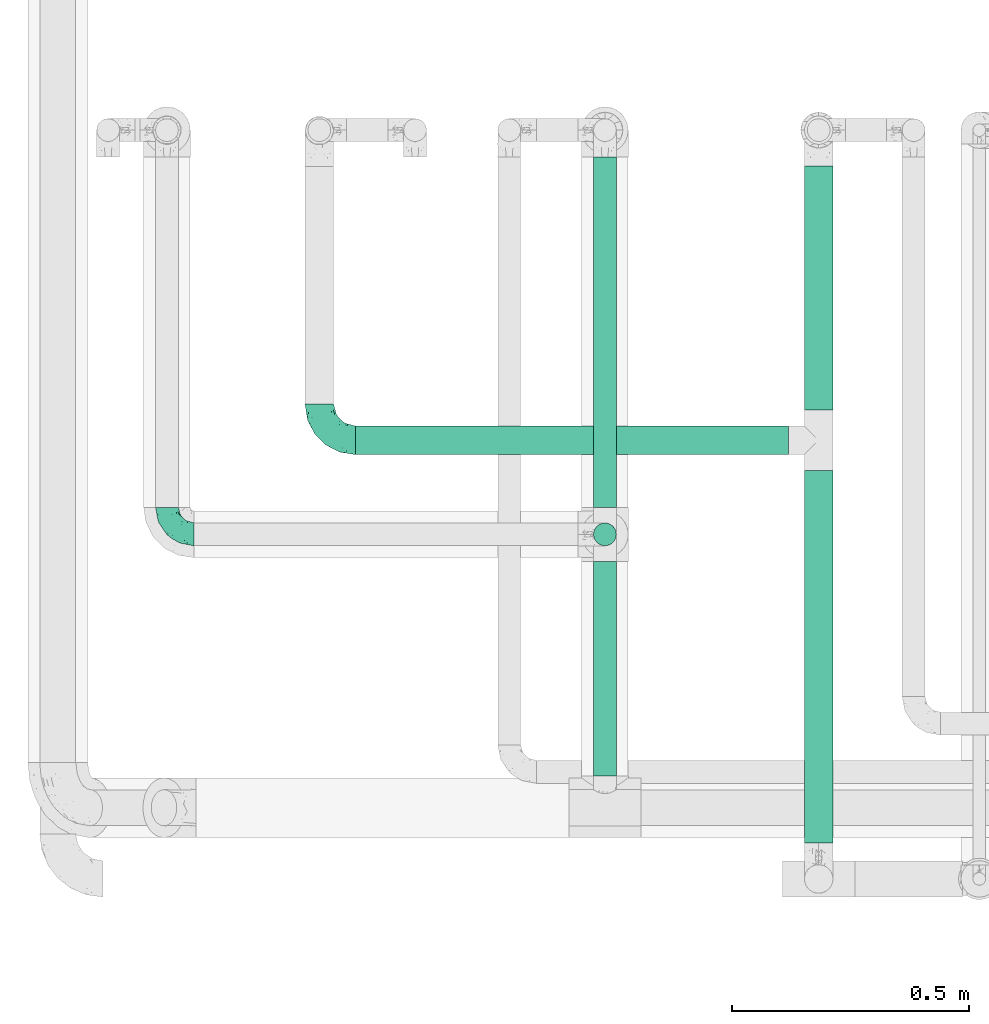
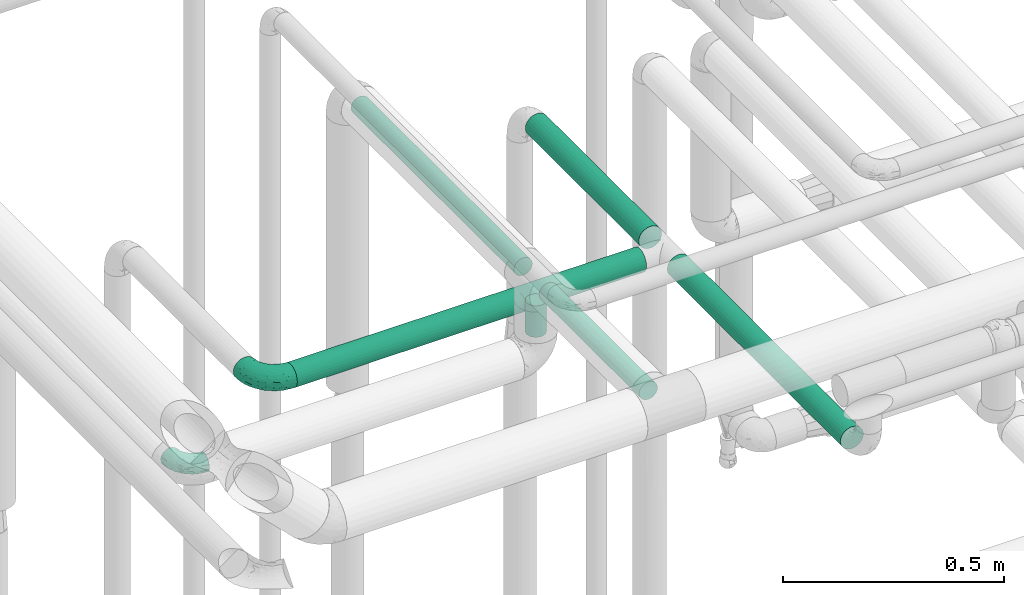
# One storey, part 695 of 827: 6 flow segments, 2 flow fittings.
"""IFC2X3 building model written with IfcOpenShell, lengths in millimetres."""

import ifcopenshell
import ifcopenshell.guid

model = None  # the IFC model being written
_history = None  # IfcOwnerHistory: only IFC2X3 demands one
_inside = {}  # id of a spatial element -> (the spatial element, [elements in it])
_under = {}  # id of a project, library or spatial element -> (it, [spatial elements below it])
_declared = {}  # id of a project -> (the project, [libraries it declares])
_typed = {}  # id of a type object -> (the type object, [elements of that type])
_made_of = {}  # id of a material, layer set ... -> (it, [elements and type objects made of it])


def new_model(schema):
    """Start an empty IFC model of exactly this schema.

    Asked for "IFC4X3", IfcOpenShell would pick the latest addendum, in which some entities
    have other attributes; the version numbers below select the first issue.
    IFC2X3 requires an IfcOwnerHistory on every rooted entity: one is made here for all.
    """
    global model, _history
    if schema == "IFC4X3":
        model = ifcopenshell.file(schema_version=(4, 3, 0, 0))
    else:
        model = ifcopenshell.file(schema=schema)
    _inside.clear()
    _under.clear()
    _declared.clear()
    _typed.clear()
    _made_of.clear()
    _history = None
    if model.schema == "IFC2X3":
        org = make("IfcOrganization", Name="unknown")
        user = make(
            "IfcPersonAndOrganization",
            ThePerson=make("IfcPerson", FamilyName="unknown"),
            TheOrganization=org,
        )
        app = make(
            "IfcApplication",
            ApplicationDeveloper=org,
            Version="unknown",
            ApplicationFullName="unknown",
            ApplicationIdentifier="unknown",
        )
        _history = make(
            "IfcOwnerHistory",
            OwningUser=user,
            OwningApplication=app,
            ChangeAction="ADDED",
            CreationDate=0,
        )
    return model


def make(cls, **values):
    """One entity of the class cls with the attributes given. An attribute that is None is left unset."""
    return model.create_entity(
        cls, **{name: value for name, value in values.items() if value is not None}
    )


def entity(cls, *values):
    """Any entity or typed value of the class cls, its attributes in the order of the schema. None: left unset."""
    e = model.create_entity(cls)
    for i, value in enumerate(values):
        if value is not None:
            e[i] = value
    return e


def rooted(cls, **values):
    """An entity with a GlobalId (a new one), such as an element, a storey or a relation."""
    return make(cls, GlobalId=ifcopenshell.guid.new(), OwnerHistory=_history, **values)


def si_unit(unit_type, name, prefix=None):
    """IfcSIUnit, for example si_unit("LENGTHUNIT", "METRE", prefix="MILLI")."""
    return make("IfcSIUnit", UnitType=unit_type, Prefix=prefix, Name=name)


def converted_unit(unit_type, name, factor, base, dimensions=None, offset=None):
    """IfcConversionBasedUnit, such as the inch: factor (a typed value) times the base unit."""
    return make(
        "IfcConversionBasedUnit"
        if offset is None
        else "IfcConversionBasedUnitWithOffset",
        ConversionOffset=offset,
        Dimensions=None
        if dimensions is None
        else entity("IfcDimensionalExponents", *dimensions),
        UnitType=unit_type,
        Name=name,
        ConversionFactor=make(
            "IfcMeasureWithUnit", ValueComponent=factor, UnitComponent=base
        ),
    )


def derived_unit(unit_type, elements):
    """IfcDerivedUnit: a product of units, each with its exponent."""
    return make(
        "IfcDerivedUnit",
        Elements=[
            make("IfcDerivedUnitElement", Unit=unit, Exponent=power)
            for unit, power in elements
        ],
        UnitType=unit_type,
    )


def assignment(units):
    """IfcUnitAssignment: the units of a project."""
    return None if units is None else make("IfcUnitAssignment", Units=units)


def point(xyz):
    """IfcCartesianPoint."""
    return None if xyz is None else make("IfcCartesianPoint", Coordinates=xyz)


def direction(xyz):
    """IfcDirection."""
    return None if xyz is None else make("IfcDirection", DirectionRatios=xyz)


def frame(location, z_axis=None, x_axis=None):
    """IfcAxis2Placement3D, a coordinate frame: its origin and axes. An axis left out is left unset."""
    return make(
        "IfcAxis2Placement3D",
        Location=point(location),
        Axis=direction(z_axis),
        RefDirection=direction(x_axis),
    )


def frame_2d(location, x_axis=None):
    """IfcAxis2Placement2D, a coordinate frame in the plane: its origin and x axis."""
    return make(
        "IfcAxis2Placement2D", Location=point(location), RefDirection=direction(x_axis)
    )


def origin():
    """The frame at (0, 0, 0) with its axes left unset."""
    return frame((0.0, 0.0, 0.0))


def origin_2d_with_axis():
    """The frame at (0, 0) in the plane with the x axis (1, 0) written out."""
    return frame_2d((0.0, 0.0), x_axis=(1.0, 0.0))


def place(relative_to, where):
    """IfcLocalPlacement: puts the frame where relative to a parent placement (None: the world)."""
    return make(
        "IfcLocalPlacement", PlacementRelTo=relative_to, RelativePlacement=where
    )


def context(
    kind, dimensions, precision=None, world=None, true_north=None, identifier=None
):
    """IfcGeometricRepresentationContext, for example the 3D "Model" context."""
    return make(
        "IfcGeometricRepresentationContext",
        ContextIdentifier=identifier,
        ContextType=kind,
        CoordinateSpaceDimension=dimensions,
        Precision=precision,
        WorldCoordinateSystem=world,
        TrueNorth=true_north,
    )


def subcontext(parent, identifier, kind, view, scale=None):
    """IfcGeometricRepresentationSubContext, for example "Body" below "Model"."""
    return make(
        "IfcGeometricRepresentationSubContext",
        ContextIdentifier=identifier,
        ContextType=kind,
        ParentContext=parent,
        TargetScale=scale,
        TargetView=view,
    )


def project(units=None, contexts=None):
    """IfcProject with its units and contexts."""
    return rooted(
        "IfcProject",
        Name="project",
        RepresentationContexts=contexts,
        UnitsInContext=assignment(units),
    )


def spatial(cls, under=None, at=None, **own):
    """A site, building, storey or space (cls), placed at a placement, below another one or the project."""
    s = rooted(cls, ObjectPlacement=at, **own)
    if under is not None:
        _under.setdefault(under.id(), (under, []))[1].append(s)
    return s


def profile(cls, at=None, kind="AREA", **sizes):
    """A parametric profile (cls). Its sizes go by their IFC names, for example OverallWidth=200.0."""
    return make(cls, ProfileType=kind, Position=at, **sizes)


def circle(**sizes):
    """IfcCircleProfileDef."""
    return profile("IfcCircleProfileDef", **sizes)


def extrude(swept, where, along, depth):
    """IfcExtrudedAreaSolid: the profile swept, set in the frame where, extruded along a direction by depth."""
    return make(
        "IfcExtrudedAreaSolid",
        SweptArea=swept,
        Position=where,
        ExtrudedDirection=direction(along),
        Depth=depth,
    )


def faces_of(points, faces, orient=None, outer=None):
    """IfcFace entities. A face is a list of loops; a loop is a list of indices into points, from 0.

    orient and outer hold one flag for each loop. By default every Orientation is true, the
    first loop of a face is its IfcFaceOuterBound and the others are IfcFaceBound.
    """
    made = []
    for i, loops in enumerate(faces):
        bounds = []
        for j, loop in enumerate(loops):
            is_outer = j == 0 if outer is None else outer[i][j]
            bounds.append(
                make(
                    "IfcFaceOuterBound" if is_outer else "IfcFaceBound",
                    Bound=make("IfcPolyLoop", Polygon=[points[k] for k in loop]),
                    Orientation=True if orient is None else orient[i][j],
                )
            )
        made.append(make("IfcFace", Bounds=bounds))
    return made


def faceted_brep(points, faces, orient=None, outer=None, voids=None):
    """IfcFacetedBrep: a solid bounded by flat faces; with voids (closed shells), ...WithVoids."""
    shared = [point(p) for p in points]
    hull = make("IfcClosedShell", CfsFaces=faces_of(shared, faces, orient, outer))
    if voids is None:
        return make("IfcFacetedBrep", Outer=hull)
    return make(
        "IfcFacetedBrepWithVoids",
        Outer=hull,
        Voids=[
            make(cls, CfsFaces=faces_of(shared, fs, o, b)) for cls, fs, o, b in voids
        ],
    )


def shape(context_of_items, identifier, shape_type, items):
    """IfcShapeRepresentation: the items that make up one representation, for example the "Body"."""
    return make(
        "IfcShapeRepresentation",
        ContextOfItems=context_of_items,
        RepresentationIdentifier=identifier,
        RepresentationType=shape_type,
        Items=items,
    )


def source(mapping_origin, context_of_items, identifier, shape_type, items):
    """IfcRepresentationMap: a shape defined once, which mapped items show again and again."""
    return make(
        "IfcRepresentationMap",
        MappingOrigin=mapping_origin,
        MappedRepresentation=shape(context_of_items, identifier, shape_type, items),
    )


def transform(
    local_origin,
    x_axis=None,
    y_axis=None,
    z_axis=None,
    scale=None,
    scale2=None,
    scale3=None,
    uniform=True,
):
    """IfcCartesianTransformationOperator3D, or its non-uniform kind. x_axis, y_axis, z_axis: its Axis1, 2, 3."""
    if uniform:
        return make(
            "IfcCartesianTransformationOperator3D",
            Axis1=direction(x_axis),
            Axis2=direction(y_axis),
            LocalOrigin=point(local_origin),
            Scale=scale,
            Axis3=direction(z_axis),
        )
    return make(
        "IfcCartesianTransformationOperator3DnonUniform",
        Axis1=direction(x_axis),
        Axis2=direction(y_axis),
        LocalOrigin=point(local_origin),
        Scale=scale,
        Axis3=direction(z_axis),
        Scale2=scale2,
        Scale3=scale3,
    )


def mapped(mapping_source, mapping_target):
    """IfcMappedItem: shows the shape of a source again, moved by a transform."""
    return make(
        "IfcMappedItem", MappingSource=mapping_source, MappingTarget=mapping_target
    )


def material(Name=None, Category=None):
    """IfcMaterial."""
    return make("IfcMaterial", Name=Name, Category=Category)


def made_of(thing, what):
    """Note that an element or type object is made of a material, layer set ...; save() writes the relation."""
    if what is not None:
        _made_of.setdefault(what.id(), (what, []))[1].append(thing)
    return thing


def type_object(cls, material=None, **own):
    """A type object (cls), such as IfcWallType, which elements share."""
    return made_of(rooted(cls, **own), material)


def type_shapes(of_type, sources):
    """Give a type object the sources (RepresentationMaps) that its elements show as mapped items."""
    of_type.RepresentationMaps = sources


def element(
    cls,
    number,
    at=None,
    inside=None,
    cuts=None,
    type_object=None,
    material=None,
    context=None,
    identifier="Body",
    shape_type=None,
    held_by="IfcProductDefinitionShape",
    body=None,
    shapes=None,
    **own,
):
    """One element of the class cls, such as IfcWall. Its Tag is "e" and its number.

    at: its placement. inside: the storey or other place that contains it. cuts: it is an
    opening in that element (IfcRelVoidsElement). A single representation is given by context,
    identifier, shape_type and body (its items); several are given by shapes. held_by: the class
    of the entity that holds the representations. save() writes the other relations.
    """
    e = rooted(cls, Tag="e%d" % number, ObjectPlacement=at, **own)
    if body is not None:
        shapes = [shape(context, identifier, shape_type, body)]
    if shapes is not None:
        e.Representation = make(held_by, Representations=shapes)
    if inside is not None:
        _inside.setdefault(inside.id(), (inside, []))[1].append(e)
    if cuts is not None:
        rooted(
            "IfcRelVoidsElement", RelatingBuildingElement=cuts, RelatedOpeningElement=e
        )
    if type_object is not None:
        _typed.setdefault(type_object.id(), (type_object, []))[1].append(e)
    return made_of(e, material)


def aggregate(whole, parts):
    """IfcRelAggregates: a whole, such as a stair, and the parts it consists of."""
    return rooted("IfcRelAggregates", RelatingObject=whole, RelatedObjects=parts)


def save(model, path):
    """Write the relations noted so far, then the file.

    IfcRelAggregates (storeys below a building ...), IfcRelContainedInSpatialStructure (elements
    in a storey), IfcRelDefinesByType, IfcRelAssociatesMaterial and IfcRelDeclares: one each for
    every whole, place, type object, material and project.
    """
    for whole, parts in _under.values():
        aggregate(whole, parts)
    for where, things in _inside.values():
        rooted(
            "IfcRelContainedInSpatialStructure",
            RelatedElements=things,
            RelatingStructure=where,
        )
    for kind, things in _typed.values():
        rooted("IfcRelDefinesByType", RelatedObjects=things, RelatingType=kind)
    for what, things in _made_of.values():
        rooted("IfcRelAssociatesMaterial", RelatedObjects=things, RelatingMaterial=what)
    for by, libraries in _declared.values():
        rooted("IfcRelDeclares", RelatingContext=by, RelatedDefinitions=libraries)
    model.write(path)


model = new_model("IFC2X3")

# Units and contexts
model_context = context("Model", 3, precision=0.01, world=origin(), true_north=direction((6.12303176911189e-17, 1.0)))
body_context = subcontext(model_context, "Body", "Model", "MODEL_VIEW")
ifc_project = project(units=[si_unit("LENGTHUNIT", "METRE", prefix="MILLI"), si_unit("AREAUNIT", "SQUARE_METRE"), si_unit("VOLUMEUNIT", "CUBIC_METRE"), converted_unit("PLANEANGLEUNIT", "DEGREE", entity("IfcRatioMeasure", 0.0174532925199433), si_unit("PLANEANGLEUNIT", "RADIAN"), dimensions=[0, 0, 0, 0, 0, 0, 0]), si_unit("MASSUNIT", "GRAM", prefix="KILO"), derived_unit("MASSDENSITYUNIT", [(si_unit("MASSUNIT", "GRAM", prefix="KILO"), 1), (si_unit("LENGTHUNIT", "METRE"), -3)]), derived_unit("MOMENTOFINERTIAUNIT", [(si_unit("LENGTHUNIT", "METRE"), 4)]), si_unit("TIMEUNIT", "SECOND"), si_unit("FREQUENCYUNIT", "HERTZ"), si_unit("THERMODYNAMICTEMPERATUREUNIT", "DEGREE_CELSIUS"), derived_unit("THERMALTRANSMITTANCEUNIT", [(si_unit("MASSUNIT", "GRAM", prefix="KILO"), 1), (si_unit("THERMODYNAMICTEMPERATUREUNIT", "KELVIN"), -1), (si_unit("TIMEUNIT", "SECOND"), -3)]), derived_unit("VOLUMETRICFLOWRATEUNIT", [(si_unit("LENGTHUNIT", "METRE"), 3), (si_unit("TIMEUNIT", "SECOND"), -1)]), derived_unit("MASSFLOWRATEUNIT", [(si_unit("MASSUNIT", "GRAM", prefix="KILO"), 1), (si_unit("TIMEUNIT", "SECOND"), -1)]), derived_unit("ROTATIONALFREQUENCYUNIT", [(si_unit("TIMEUNIT", "SECOND"), -1)]), si_unit("ELECTRICCURRENTUNIT", "AMPERE"), si_unit("ELECTRICVOLTAGEUNIT", "VOLT"), si_unit("POWERUNIT", "WATT"), si_unit("FORCEUNIT", "NEWTON", prefix="KILO"), si_unit("ILLUMINANCEUNIT", "LUX"), si_unit("LUMINOUSFLUXUNIT", "LUMEN"), si_unit("LUMINOUSINTENSITYUNIT", "CANDELA"), derived_unit("USERDEFINED", [(si_unit("MASSUNIT", "GRAM", prefix="KILO"), -1), (si_unit("LENGTHUNIT", "METRE"), -2), (si_unit("TIMEUNIT", "SECOND"), 3), (si_unit("LUMINOUSFLUXUNIT", "LUMEN"), 1)]), derived_unit("LINEARVELOCITYUNIT", [(si_unit("LENGTHUNIT", "METRE"), 1), (si_unit("TIMEUNIT", "SECOND"), -1)]), si_unit("PRESSUREUNIT", "PASCAL"), derived_unit("USERDEFINED", [(si_unit("LENGTHUNIT", "METRE"), -2), (si_unit("MASSUNIT", "GRAM", prefix="KILO"), 1), (si_unit("TIMEUNIT", "SECOND"), -2)]), derived_unit("LINEARFORCEUNIT", [(si_unit("MASSUNIT", "GRAM", prefix="KILO"), 1), (si_unit("LENGTHUNIT", "METRE"), 1), (si_unit("TIMEUNIT", "SECOND"), -2), (si_unit("LENGTHUNIT", "METRE"), -1)]), derived_unit("PLANARFORCEUNIT", [(si_unit("MASSUNIT", "GRAM", prefix="KILO"), 1), (si_unit("LENGTHUNIT", "METRE"), 1), (si_unit("TIMEUNIT", "SECOND"), -2), (si_unit("LENGTHUNIT", "METRE"), -2)])], contexts=[model_context])

# Site, building, storey
site_placement = place(None, origin())
site = spatial("IfcSite", under=ifc_project, at=site_placement, CompositionType="ELEMENT")
building_placement = place(site_placement, origin())
building = spatial("IfcBuilding", under=site, at=building_placement, CompositionType="ELEMENT")
storey_placement = place(building_placement, frame((0.0, 0.0, 28200.0)))
storey = spatial("IfcBuildingStorey", under=building, at=storey_placement, Name="08", CompositionType="ELEMENT", Elevation=28200.0)

# Flow segments
pipe_segment_type = type_object("IfcPipeSegmentType", PredefinedType="NOTDEFINED")
flow_segment_1_placement = place(storey_placement, frame((52595.38, 16814.9, 2466.57)))
element("IfcFlowSegment", 1, at=flow_segment_1_placement, inside=storey, type_object=pipe_segment_type, context=body_context, shape_type="SweptSolid", body=[
    extrude(circle(Radius=30.0, at=origin_2d_with_axis()), frame((0.0, 31.6, 31.6), z_axis=(1.0, 0.0, 0.0), x_axis=(0.0, -1.0, 0.0)), (0.0, 0.0, 1.0), 912.026270000026),
])
flow_segment_2_placement = place(storey_placement, frame((53539.81, 16910.5, 2466.57)))
element("IfcFlowSegment", 2, at=flow_segment_2_placement, inside=storey, type_object=pipe_segment_type, context=body_context, shape_type="SweptSolid", body=[
    extrude(circle(Radius=30.0, at=origin_2d_with_axis()), frame((31.6, 0.0, 31.6), z_axis=(0.0, 1.0, 0.0), x_axis=(1.0, 0.0, 0.0)), (0.0, 0.0, 1.0), 513.501961460822),
])
flow_segment_3_placement = place(storey_placement, frame((53539.81, 15998.38, 2466.57)))
element("IfcFlowSegment", 3, at=flow_segment_3_placement, inside=storey, type_object=pipe_segment_type, context=body_context, shape_type="SweptSolid", body=[
    extrude(circle(Radius=30.0, at=origin_2d_with_axis()), frame((31.6, 0.0, 31.6), z_axis=(0.0, 1.0, 0.0), x_axis=(-1.0, 0.0, 0.0)), (0.0, 0.0, 1.0), 784.120734895226),
])
flow_segment_4_placement = place(storey_placement, frame((53095.46, 16139.34, 2673.82)))
element("IfcFlowSegment", 4, at=flow_segment_4_placement, inside=storey, type_object=pipe_segment_type, context=body_context, shape_type="SweptSolid", body=[
    extrude(circle(Radius=24.0, at=origin_2d_with_axis()), frame((25.6, 452.04, 25.6), z_axis=(0.0, -0.999999057686602, 0.00137281677842283), x_axis=(-1.0, 0.0, 0.0)), (0.0, 0.0, 1.0), 452.00943964707),
])
flow_segment_5_placement = place(storey_placement, frame((53095.46, 16622.71, 2555.16)))
element("IfcFlowSegment", 5, at=flow_segment_5_placement, inside=storey, type_object=pipe_segment_type, context=body_context, shape_type="SweptSolid", body=[
    extrude(circle(Radius=24.0, at=origin_2d_with_axis()), frame((25.6, 25.64, 0.01), z_axis=(0.0, -0.000542908855839149, 0.999999852624976), x_axis=(1.0, 0.0, 0.0)), (0.0, 0.0, 1.0), 87.1320315967125),
])
flow_segment_6_placement = place(storey_placement, frame((53095.46, 16705.35, 2672.65)))
element("IfcFlowSegment", 6, at=flow_segment_6_placement, inside=storey, type_object=pipe_segment_type, context=body_context, shape_type="SweptSolid", body=[
    extrude(circle(Radius=24.0, at=origin_2d_with_axis()), frame((25.6, 0.03, 26.61), z_axis=(0.0, 0.999999057686603, -0.00137281677839721), x_axis=(-1.0, 0.0, 0.0)), (0.0, 0.0, 1.0), 737.692684756272),
])

# Flow fittings
ifc_material = material()
pipe_fitting_type_1 = type_object("IfcPipeFittingType", Name="ADSK_1", PredefinedType="NOTDEFINED", material=ifc_material)
shared_shape_1 = source(origin(), body_context, "Body", "Brep", [
    faceted_brep([(-57.0, 12.07, -20.91), (-57.0, 6.25, -23.33), (-57.0, 0.0, -24.15), (-57.0, -6.25, -23.33), (-57.0, -12.08, -20.91), (-57.0, -17.08, -17.08), (-57.0, -20.91, -12.08), (-57.0, -23.33, -6.25), (-57.0, -24.15, 0.0), (-57.0, -23.33, 6.25), (-57.0, -20.91, 12.07), (-57.0, -17.08, 17.08), (-57.0, -12.08, 20.91), (-57.0, -6.25, 23.33), (-57.0, 0.0, 24.15), (-57.0, 6.25, 23.33), (-57.0, 12.07, 20.91), (-57.0, 17.08, 17.08), (-57.0, 20.91, 12.07), (-57.0, 23.33, 6.25), (-57.0, 24.15, 0.0), (-57.0, 23.33, -6.25), (-57.0, 20.91, -12.08), (-57.0, 17.08, -17.08), (0.0, 57.0, -24.15), (-6.25, 57.0, -23.33), (-12.07, 57.0, -20.91), (-17.08, 57.0, -17.08), (-20.91, 57.0, -12.08), (-23.33, 57.0, -6.25), (-24.15, 57.0, 0.0), (-23.33, 57.0, 6.25), (-20.91, 57.0, 12.07), (-17.08, 57.0, 17.08), (-12.07, 57.0, 20.91), (-6.25, 57.0, 23.33), (0.0, 57.0, 24.15), (6.25, 57.0, 23.33), (12.08, 57.0, 20.91), (17.08, 57.0, 17.08), (20.91, 57.0, 12.07), (23.33, 57.0, 6.25), (24.15, 57.0, 0.0), (23.33, 57.0, -6.25), (20.91, 57.0, -12.08), (17.08, 57.0, -17.08), (12.08, 57.0, -20.91), (6.25, 57.0, -23.33), (14.9, 21.14, 6.17), (13.61, 24.64, 12.48), (6.23, 8.95, 8.98), (-41.47, -21.06, 0.0), (-41.92, -18.38, 13.72), (-24.64, -13.61, 12.48), (-37.37, -13.24, 18.15), (-6.8, -4.93, 8.18), (-21.76, -15.19, 6.22), (-12.78, -9.18, 0.0), (-37.73, -20.51, 7.75), (-7.38, 7.38, 20.24), (-23.37, -4.26, 20.42), (-11.9, -3.19, 15.86), (-42.14, -8.7, 21.82), (13.24, 37.37, 18.15), (9.33, 23.53, 16.85), (4.26, 23.37, 20.42), (2.77, 10.92, 15.55), (-29.46, 0.91, 23.52), (-44.13, 20.56, 15.69), (-39.25, 26.33, 10.88), (-49.02, 22.92, 9.96), (-34.58, 23.87, 17.15), (-15.8, 6.8, 22.81), (-8.67, 20.47, 23.88), (-18.12, 12.9, 24.08), (-48.29, 14.92, 19.65), (-44.06, -2.85, 23.78), (-9.23, 48.95, 22.58), (-3.78, 42.74, 24.07), (-40.34, 4.26, 24.09), (-44.02, 26.14, 5.46), (-44.04, 9.88, 22.74), (-4.95, 16.87, 22.52), (-2.75, 1.43, 12.5), (-25.48, 40.98, 10.71), (20.51, 37.73, 7.75), (18.38, 41.92, 13.72), (8.7, 42.14, 21.82), (-25.95, -17.97, 0.0), (2.85, 44.06, 23.78), (21.06, 41.47, 0.0), (17.97, 25.95, 0.0), (-24.04, -9.27, 17.13), (-33.26, 33.26, 5.86), (-28.55, 40.57, 0.0), (-40.57, 28.55, 0.0), (-25.29, 47.19, 4.06), (-27.01, 31.1, 16.77), (-15.7, 43.95, 19.9), (-20.27, 45.22, 15.61), (-30.53, 31.98, 12.64), (-11.28, 38.33, 22.92), (-9.97, 27.88, 24.09), (-20.15, 30.26, 21.25), (-31.25, 11.75, 23.64), (-28.75, 7.23, 24.15), (-29.53, 18.06, 22.27), (-28.44, 24.21, 20.02), (-37.55, 17.7, 20.26), (-15.88, 29.25, 22.99), (-20.82, 20.82, 23.44), (-0.91, 29.46, 23.52), (-13.5, -7.67, 12.04), (1.49, 1.56, 5.16), (8.86, 10.35, 4.59), (0.38, -0.38, 0.0), (9.18, 12.78, 0.0), (-37.37, -13.24, -18.15), (8.86, 10.35, -4.59), (-45.22, 20.27, -15.61), (-43.95, 15.7, -19.9), (-38.33, 11.28, -22.92), (-48.95, 9.23, -22.58), (-47.19, 25.29, -4.06), (-33.26, 33.26, -5.86), (18.38, 41.92, -13.72), (-30.26, 20.15, -21.25), (2.85, 44.06, -23.78), (-4.26, 40.34, -24.09), (-40.98, 25.48, -10.71), (-41.92, -18.38, -13.72), (9.25, 23.5, -16.92), (4.26, 23.37, -20.42), (13.24, 37.37, -18.15), (-37.73, -20.51, -7.75), (-11.75, 31.25, -23.64), (-7.23, 28.75, -24.15), (-12.9, 18.12, -24.08), (8.7, 42.14, -21.82), (-44.06, -2.85, -23.78), (-6.8, 15.8, -22.81), (-20.47, 8.67, -23.88), (-24.64, -13.61, -12.48), (-42.74, 3.78, -24.07), (-18.06, 29.53, -22.27), (-24.21, 28.44, -20.02), (-27.88, 9.97, -24.09), (-31.1, 27.01, -16.77), (-26.14, 44.02, -5.46), (14.9, 21.14, -6.17), (20.51, 37.73, -7.75), (-9.88, 44.04, -22.74), (-20.56, 44.13, -15.69), (-21.76, -15.19, -6.22), (-13.5, -7.67, -12.04), (-24.14, -9.76, -16.74), (-11.9, -3.19, -15.86), (-14.92, 48.29, -19.65), (-23.37, -4.26, -20.42), (-0.91, 29.46, -23.52), (-26.33, 39.25, -10.88), (-23.87, 34.58, -17.15), (-42.14, -8.7, -21.82), (-22.92, 49.02, -9.96), (13.61, 24.64, -12.48), (-31.98, 30.53, -12.64), (-16.87, 4.95, -22.52), (-17.7, 37.55, -20.26), (-29.25, 15.88, -22.99), (-20.82, 20.82, -23.44), (-29.46, 0.91, -23.52), (-7.38, 7.38, -20.24), (2.77, 10.92, -15.55), (6.23, 8.95, -8.98), (-6.8, -4.93, -8.18), (-2.81, 1.41, -12.54), (1.49, 1.56, -5.16)], [[[0, 1, 2, 3, 4, 5, 6, 7, 8, 9, 10, 11, 12, 13, 14, 15, 16, 17, 18, 19, 20, 21, 22, 23]], [[24, 25, 26, 27, 28, 29, 30, 31, 32, 33, 34, 35, 36, 37, 38, 39, 40, 41, 42, 43, 44, 45, 46, 47]], [[48, 49, 50]], [[9, 8, 51]], [[52, 53, 54]], [[55, 56, 57]], [[10, 58, 52]], [[9, 58, 10]], [[59, 60, 61]], [[54, 12, 11]], [[54, 62, 12]], [[63, 39, 38]], [[64, 65, 66]], [[62, 60, 67]], [[68, 69, 70]], [[71, 69, 68]], [[72, 73, 74]], [[16, 75, 17]], [[13, 76, 14]], [[35, 77, 78]], [[14, 79, 15]], [[17, 68, 18]], [[14, 76, 79]], [[20, 19, 80]], [[70, 19, 18]], [[81, 15, 79]], [[15, 81, 16]], [[73, 72, 82]], [[66, 83, 50]], [[32, 31, 84]], [[85, 86, 49]], [[63, 87, 65]], [[56, 58, 88]], [[36, 89, 37]], [[85, 41, 40]], [[36, 35, 78]], [[90, 41, 85]], [[40, 39, 86]], [[12, 62, 13]], [[86, 85, 40]], [[48, 85, 49]], [[85, 91, 90]], [[87, 38, 37]], [[92, 60, 54]], [[80, 69, 93]], [[93, 94, 95]], [[10, 52, 11]], [[94, 96, 30]], [[97, 98, 99]], [[80, 93, 95]], [[100, 97, 84]], [[99, 98, 33]], [[101, 102, 78]], [[103, 101, 98]], [[96, 31, 30]], [[77, 98, 101]], [[77, 35, 34]], [[34, 33, 98]], [[9, 51, 58]], [[87, 63, 38]], [[104, 105, 74]], [[106, 103, 107]], [[106, 81, 104]], [[75, 68, 17]], [[108, 107, 71]], [[33, 32, 99]], [[109, 103, 110]], [[101, 109, 102]], [[89, 78, 111]], [[53, 52, 58]], [[54, 11, 52]], [[60, 62, 54]], [[88, 58, 51]], [[76, 62, 67]], [[53, 112, 92]], [[60, 59, 72]], [[39, 63, 86]], [[49, 86, 63]], [[89, 87, 37]], [[42, 41, 90]], [[111, 82, 65]], [[111, 65, 87]], [[65, 59, 66]], [[104, 81, 79]], [[75, 81, 108]], [[32, 84, 99]], [[97, 99, 84]], [[98, 97, 103]], [[106, 107, 108]], [[74, 102, 110]], [[111, 78, 102]], [[74, 110, 104]], [[74, 67, 72]], [[61, 92, 112]], [[66, 59, 61]], [[56, 53, 58]], [[66, 50, 49]], [[61, 112, 83]], [[66, 49, 64]], [[78, 89, 36]], [[87, 89, 111]], [[62, 76, 13]], [[79, 76, 67]], [[100, 93, 69]], [[96, 93, 84]], [[55, 113, 50]], [[113, 114, 50]], [[104, 79, 105]], [[106, 104, 110]], [[20, 80, 95]], [[85, 48, 91]], [[115, 114, 113]], [[116, 91, 48]], [[70, 80, 19]], [[93, 96, 94]], [[84, 31, 96]], [[103, 106, 110]], [[81, 106, 108]], [[103, 97, 107]], [[71, 107, 97]], [[71, 97, 100]], [[108, 71, 68]], [[79, 67, 105]], [[67, 74, 105]], [[115, 113, 57]], [[112, 56, 55]], [[56, 88, 57]], [[60, 72, 67]], [[82, 72, 59]], [[65, 82, 59]], [[82, 111, 73]], [[111, 102, 73]], [[102, 74, 73]], [[81, 75, 16]], [[68, 75, 108]], [[68, 70, 18]], [[80, 70, 69]], [[98, 77, 34]], [[78, 77, 101]], [[93, 100, 84]], [[71, 100, 69]], [[102, 109, 110]], [[101, 103, 109]], [[53, 92, 54]], [[61, 60, 92]], [[56, 112, 53]], [[83, 112, 55]], [[50, 83, 55]], [[61, 83, 66]], [[49, 63, 64]], [[65, 64, 63]], [[57, 113, 55]], [[114, 115, 116]], [[116, 48, 114]], [[48, 50, 114]], [[117, 5, 4]], [[116, 115, 118]], [[119, 120, 23]], [[121, 122, 120]], [[95, 123, 20]], [[0, 23, 120]], [[124, 95, 94]], [[125, 45, 44]], [[121, 120, 126]], [[24, 127, 128]], [[22, 21, 129]], [[0, 122, 1]], [[5, 117, 130]], [[131, 132, 133]], [[134, 88, 51]], [[135, 136, 137]], [[6, 5, 130]], [[46, 138, 47]], [[139, 3, 2]], [[140, 141, 137]], [[6, 134, 7]], [[134, 130, 142]], [[143, 2, 1]], [[144, 126, 145]], [[121, 146, 143]], [[147, 120, 119]], [[94, 148, 124]], [[149, 150, 91]], [[30, 29, 148]], [[151, 25, 128]], [[27, 152, 28]], [[134, 153, 88]], [[154, 155, 156]], [[27, 26, 157]], [[151, 26, 25]], [[155, 158, 156]], [[24, 47, 127]], [[1, 122, 143]], [[138, 132, 159]], [[160, 152, 161]], [[24, 128, 25]], [[46, 133, 138]], [[162, 117, 4]], [[148, 160, 124]], [[152, 160, 163]], [[154, 142, 155]], [[45, 125, 133]], [[133, 46, 45]], [[125, 164, 133]], [[51, 7, 134]], [[42, 90, 43]], [[165, 147, 129]], [[153, 134, 142]], [[43, 150, 44]], [[162, 4, 3]], [[141, 140, 166]], [[117, 162, 158]], [[163, 29, 28]], [[43, 90, 150]], [[123, 21, 20]], [[144, 151, 135]], [[157, 152, 27]], [[167, 145, 161]], [[23, 22, 119]], [[168, 126, 169]], [[121, 168, 146]], [[139, 143, 170]], [[142, 130, 117]], [[8, 7, 51]], [[134, 6, 130]], [[139, 162, 3]], [[170, 166, 158]], [[170, 158, 162]], [[158, 171, 156]], [[44, 150, 125]], [[91, 150, 90]], [[164, 125, 150]], [[132, 138, 133]], [[127, 138, 159]], [[131, 164, 172]], [[132, 171, 140]], [[135, 151, 128]], [[157, 151, 167]], [[22, 129, 119]], [[147, 119, 129]], [[120, 147, 126]], [[144, 145, 167]], [[137, 146, 169]], [[170, 143, 146]], [[137, 169, 135]], [[137, 159, 140]], [[171, 172, 156]], [[173, 174, 175]], [[156, 175, 154]], [[174, 57, 153]], [[132, 172, 171]], [[172, 164, 173]], [[143, 139, 2]], [[162, 139, 170]], [[138, 127, 47]], [[128, 127, 159]], [[165, 124, 160]], [[123, 124, 129]], [[149, 173, 164]], [[176, 174, 173]], [[135, 128, 136]], [[144, 135, 169]], [[150, 149, 164]], [[176, 118, 115]], [[149, 91, 116]], [[30, 148, 94]], [[163, 148, 29]], [[124, 123, 95]], [[129, 21, 123]], [[126, 144, 169]], [[151, 144, 167]], [[126, 147, 145]], [[161, 145, 147]], [[161, 147, 165]], [[167, 161, 152]], [[128, 159, 136]], [[159, 137, 136]], [[154, 153, 142]], [[132, 140, 159]], [[174, 176, 57]], [[57, 88, 153]], [[166, 140, 171]], [[158, 166, 171]], [[166, 170, 141]], [[170, 146, 141]], [[146, 137, 141]], [[151, 157, 26]], [[152, 157, 167]], [[152, 163, 28]], [[148, 163, 160]], [[120, 122, 0]], [[143, 122, 121]], [[124, 165, 129]], [[161, 165, 160]], [[146, 168, 169]], [[121, 126, 168]], [[142, 117, 155]], [[158, 155, 117]], [[175, 156, 172]], [[153, 154, 174]], [[173, 175, 172]], [[174, 154, 175]], [[164, 131, 133]], [[172, 132, 131]], [[176, 173, 118]], [[57, 176, 115]], [[173, 149, 118]], [[149, 116, 118]]]),
])
type_shapes(pipe_fitting_type_1, [shared_shape_1])
flow_fitting_1_placement = place(storey_placement, frame((52198.28, 16648.39, 2498.17), z_axis=(0.0, 0.0, 1.0), x_axis=(0.0, -1.0, 0.0)))
element("IfcFlowFitting", 7, at=flow_fitting_1_placement, inside=storey, type_object=pipe_fitting_type_1, material=ifc_material, Name="ADSK_1", ObjectType="ADSK_1", context=body_context, shape_type="MappedRepresentation", body=[
    mapped(shared_shape_1, transform((0.0, 0.0, 0.0), scale=1.0)),
])
pipe_fitting_type_2 = type_object("IfcPipeFittingType", Name="ADSK_1", PredefinedType="NOTDEFINED", material=ifc_material)
shared_shape_2 = source(origin(), body_context, "Body", "Brep", [
    faceted_brep([(-76.0, 15.07, -26.11), (-76.0, 7.8, -29.12), (-76.0, 0.0, -30.15), (-76.0, -7.8, -29.12), (-76.0, -15.08, -26.11), (-76.0, -21.32, -21.32), (-76.0, -26.11, -15.08), (-76.0, -29.12, -7.8), (-76.0, -30.15, 0.0), (-76.0, -29.12, 7.8), (-76.0, -26.11, 15.07), (-76.0, -21.32, 21.32), (-76.0, -15.08, 26.11), (-76.0, -7.8, 29.12), (-76.0, 0.0, 30.15), (-76.0, 7.8, 29.12), (-76.0, 15.07, 26.11), (-76.0, 21.32, 21.32), (-76.0, 26.11, 15.07), (-76.0, 29.12, 7.8), (-76.0, 30.15, 0.0), (-76.0, 29.12, -7.8), (-76.0, 26.11, -15.08), (-76.0, 21.32, -21.32), (0.0, 76.0, -30.15), (-7.8, 76.0, -29.12), (-15.07, 76.0, -26.11), (-21.32, 76.0, -21.32), (-26.11, 76.0, -15.08), (-29.12, 76.0, -7.8), (-30.15, 76.0, 0.0), (-29.12, 76.0, 7.8), (-26.11, 76.0, 15.07), (-21.32, 76.0, 21.32), (-15.07, 76.0, 26.11), (-7.8, 76.0, 29.12), (0.0, 76.0, 30.15), (7.8, 76.0, 29.12), (15.08, 76.0, 26.11), (21.32, 76.0, 21.32), (26.11, 76.0, 15.07), (29.12, 76.0, 7.8), (30.15, 76.0, 0.0), (29.12, 76.0, -7.8), (26.11, 76.0, -15.08), (21.32, 76.0, -21.32), (15.08, 76.0, -26.11), (7.8, 76.0, -29.12), (10.79, 31.43, 21.07), (4.32, 31.7, 25.72), (1.65, 15.19, 19.92), (-61.17, -27.8, 0.0), (-51.1, -25.49, 9.84), (-56.14, -10.61, 27.27), (-31.7, -4.32, 25.72), (-39.75, 1.72, 29.41), (-43.2, -24.95, 0.0), (-1.86, 1.86, 0.0), (4.49, 7.65, 5.78), (-7.82, -4.61, 5.83), (-56.21, -22.79, 17.21), (-58.98, -3.38, 29.7), (-53.96, 5.6, 30.07), (-10.86, 10.86, 25.48), (-17.2, -2.6, 20.44), (-49.15, -16.01, 22.7), (-22.18, -14.24, 7.99), (-28.4, -17.42, 0.0), (-13.61, -9.88, 0.0), (-39.0, 23.48, 27.76), (-58.76, 12.54, 28.36), (-41.61, 15.41, 29.48), (16.01, 49.15, 22.7), (-58.55, 25.93, 19.53), (-51.53, 33.5, 13.51), (-64.92, 28.76, 12.4), (-7.48, 23.14, 28.25), (-1.72, 39.75, 29.41), (-12.04, 27.88, 29.88), (-63.91, 18.81, 24.52), (-11.63, 65.16, 28.18), (-4.97, 57.02, 30.05), (9.88, 13.61, 0.0), (-62.5, 31.74, 5.02), (-45.17, 30.98, 21.2), (-21.78, 9.76, 28.58), (10.61, 56.14, 27.27), (-32.09, 54.42, 13.26), (22.79, 56.21, 17.21), (15.38, 31.17, 15.63), (25.49, 51.1, 9.84), (21.84, 36.35, 5.92), (24.95, 43.2, 0.0), (3.38, 58.98, 29.7), (-31.17, -15.38, 15.63), (-39.39, 41.78, 15.45), (-34.56, 41.13, 20.79), (-39.81, -23.25, 5.49), (27.8, 61.17, 0.0), (-31.74, 62.5, 5.02), (-53.07, 36.29, 0.0), (-42.95, 42.95, 7.29), (-36.29, 53.07, 0.0), (-19.83, 58.51, 24.79), (-25.48, 60.2, 19.41), (-14.53, 50.96, 28.57), (-13.31, 37.09, 30.07), (-26.16, 40.06, 26.4), (-32.43, -10.35, 21.9), (17.42, 28.4, 0.0), (14.24, 22.18, 7.99), (-38.67, 9.72, 30.15), (-24.66, 17.36, 30.09), (-37.08, 31.49, 24.99), (-49.27, 22.83, 25.24), (-20.8, 38.81, 28.63), (-27.58, 27.58, 29.2), (-36.07, -20.23, 10.71), (-15.19, -6.16, 14.9), (6.6, 15.4, 14.49), (-2.51, 2.51, 11.35), (-65.16, 11.63, -28.18), (-49.15, -16.01, -22.7), (-57.02, 4.97, -30.05), (-25.93, 58.55, -19.53), (-33.5, 51.53, -13.51), (-28.76, 64.92, -12.4), (-60.2, 25.48, -19.41), (-58.51, 19.83, -24.79), (4.61, 7.82, -5.83), (-7.65, -4.49, -5.78), (-2.51, 2.51, -11.35), (-62.5, 31.74, -5.02), (-50.96, 14.53, -28.57), (-37.09, 13.31, -30.07), (-42.95, 42.95, -7.29), (25.49, 51.1, -9.84), (22.79, 56.21, -17.21), (-40.06, 26.16, -26.4), (3.38, 58.98, -29.7), (-5.6, 53.96, -30.07), (-27.88, 12.04, -29.88), (-9.76, 21.78, -28.58), (-23.14, 7.48, -28.25), (-51.1, -25.49, -9.84), (15.38, 31.17, -15.63), (16.01, 49.15, -22.7), (-23.48, 39.0, -27.76), (-12.54, 58.76, -28.36), (-15.41, 41.61, -29.48), (-56.21, -22.79, -17.21), (-9.72, 38.67, -30.15), (-17.36, 24.66, -30.09), (-22.18, -14.24, -7.99), (-41.13, 34.56, -20.79), (-31.74, 62.5, -5.02), (-58.98, -3.38, -29.7), (-31.17, -15.38, -15.63), (-56.14, -10.61, -27.27), (14.24, 22.18, -7.99), (23.25, 39.81, -5.49), (-31.49, 37.08, -24.99), (-15.19, -6.16, -14.9), (1.65, 15.19, -19.92), (-18.81, 63.91, -24.52), (-32.59, -11.62, -20.84), (-31.7, -4.32, -25.72), (-17.2, -2.6, -20.44), (-39.75, 1.72, -29.41), (-54.42, 32.09, -13.26), (-30.98, 45.17, -21.2), (10.61, 56.14, -27.27), (10.23, 31.31, -21.52), (4.32, 31.7, -25.72), (-41.78, 39.39, -15.45), (-1.72, 39.75, -29.41), (-36.35, -21.84, -5.92), (-22.83, 49.27, -25.24), (-38.81, 20.8, -28.63), (-27.58, 27.58, -29.2), (-10.86, 10.86, -25.48), (20.23, 36.07, -10.71), (6.6, 15.4, -14.49)], [[[0, 1, 2, 3, 4, 5, 6, 7, 8, 9, 10, 11, 12, 13, 14, 15, 16, 17, 18, 19, 20, 21, 22, 23]], [[24, 25, 26, 27, 28, 29, 30, 31, 32, 33, 34, 35, 36, 37, 38, 39, 40, 41, 42, 43, 44, 45, 46, 47]], [[48, 49, 50]], [[51, 52, 9]], [[53, 54, 55]], [[9, 52, 10]], [[56, 52, 51]], [[57, 58, 59]], [[11, 10, 60]], [[14, 61, 62]], [[63, 54, 64]], [[65, 12, 11]], [[65, 53, 12]], [[66, 67, 68]], [[69, 70, 71]], [[72, 39, 38]], [[73, 74, 75]], [[15, 70, 16]], [[76, 77, 78]], [[16, 79, 17]], [[13, 61, 14]], [[35, 80, 81]], [[14, 62, 15]], [[17, 73, 18]], [[57, 82, 58]], [[20, 19, 83]], [[75, 19, 18]], [[70, 15, 62]], [[73, 84, 74]], [[78, 85, 76]], [[38, 86, 72]], [[32, 31, 87]], [[88, 89, 90]], [[91, 92, 90]], [[72, 86, 49]], [[36, 93, 37]], [[75, 83, 19]], [[36, 35, 81]], [[60, 94, 65]], [[40, 90, 41]], [[95, 96, 87]], [[88, 90, 40]], [[66, 97, 67]], [[90, 98, 41]], [[40, 39, 88]], [[99, 31, 30]], [[20, 83, 100]], [[101, 102, 100]], [[52, 60, 10]], [[102, 99, 30]], [[96, 103, 104]], [[83, 101, 100]], [[12, 53, 13]], [[104, 103, 33]], [[105, 106, 81]], [[107, 105, 103]], [[64, 54, 108]], [[80, 103, 105]], [[80, 35, 34]], [[34, 33, 103]], [[86, 38, 37]], [[109, 110, 82]], [[71, 111, 112]], [[69, 107, 113]], [[79, 73, 17]], [[114, 113, 84]], [[33, 32, 104]], [[115, 107, 116]], [[105, 115, 106]], [[93, 81, 77]], [[54, 53, 65]], [[61, 53, 55]], [[108, 94, 64]], [[54, 63, 85]], [[93, 86, 37]], [[77, 76, 49]], [[77, 49, 86]], [[49, 63, 50]], [[60, 52, 117]], [[65, 11, 60]], [[39, 72, 88]], [[89, 88, 72]], [[71, 70, 62]], [[79, 70, 114]], [[103, 96, 107]], [[69, 113, 114]], [[112, 106, 116]], [[77, 81, 106]], [[112, 116, 71]], [[112, 55, 85]], [[64, 50, 63]], [[57, 59, 68]], [[32, 87, 104]], [[96, 104, 87]], [[94, 118, 64]], [[50, 119, 89]], [[50, 64, 118]], [[50, 89, 48]], [[81, 93, 36]], [[86, 93, 77]], [[53, 61, 13]], [[62, 61, 55]], [[71, 62, 111]], [[69, 71, 116]], [[95, 101, 74]], [[99, 101, 87]], [[118, 66, 59]], [[117, 97, 66]], [[117, 66, 94]], [[91, 89, 110]], [[91, 110, 109]], [[110, 89, 119]], [[9, 8, 51]], [[98, 90, 92]], [[98, 42, 41]], [[101, 83, 74]], [[101, 99, 102]], [[87, 31, 99]], [[62, 55, 111]], [[55, 112, 111]], [[107, 69, 116]], [[70, 69, 114]], [[107, 96, 113]], [[84, 113, 96]], [[84, 96, 95]], [[114, 84, 73]], [[70, 79, 16]], [[73, 79, 114]], [[54, 85, 55]], [[76, 85, 63]], [[49, 76, 63]], [[77, 106, 78]], [[106, 112, 78]], [[85, 78, 112]], [[73, 75, 18]], [[83, 75, 74]], [[103, 80, 34]], [[81, 80, 105]], [[101, 95, 87]], [[84, 95, 74]], [[106, 115, 116]], [[105, 107, 115]], [[120, 59, 58]], [[82, 110, 58]], [[119, 58, 110]], [[118, 59, 120]], [[66, 68, 59]], [[54, 65, 108]], [[94, 108, 65]], [[66, 118, 94]], [[50, 118, 120]], [[50, 120, 119]], [[119, 120, 58]], [[89, 72, 48]], [[49, 48, 72]], [[60, 117, 94]], [[117, 52, 97]], [[52, 56, 97]], [[67, 97, 56]], [[92, 91, 109]], [[89, 91, 90]], [[121, 1, 0]], [[122, 5, 4]], [[2, 1, 123]], [[124, 125, 126]], [[127, 128, 23]], [[129, 130, 131]], [[100, 132, 20]], [[133, 134, 123]], [[135, 100, 102]], [[136, 137, 44]], [[133, 128, 138]], [[24, 139, 140]], [[141, 142, 143]], [[121, 128, 133]], [[6, 144, 7]], [[137, 145, 146]], [[144, 51, 7]], [[147, 148, 149]], [[144, 6, 150]], [[149, 151, 152]], [[153, 68, 67]], [[154, 128, 127]], [[30, 155, 102]], [[43, 42, 98]], [[156, 3, 2]], [[157, 144, 150]], [[158, 4, 3]], [[24, 140, 25]], [[155, 135, 102]], [[159, 160, 109]], [[30, 29, 155]], [[147, 138, 161]], [[27, 124, 28]], [[57, 129, 82]], [[162, 163, 131]], [[27, 26, 164]], [[148, 26, 25]], [[165, 166, 167]], [[24, 47, 139]], [[143, 168, 141]], [[22, 21, 169]], [[125, 124, 170]], [[148, 25, 140]], [[46, 146, 171]], [[158, 122, 4]], [[0, 23, 128]], [[1, 121, 123]], [[109, 82, 159]], [[45, 44, 137]], [[146, 46, 45]], [[136, 43, 98]], [[132, 21, 20]], [[136, 98, 92]], [[172, 173, 146]], [[46, 171, 47]], [[43, 136, 44]], [[174, 154, 169]], [[171, 173, 175]], [[6, 5, 150]], [[126, 29, 28]], [[176, 56, 144]], [[122, 158, 166]], [[164, 124, 27]], [[177, 161, 170]], [[23, 22, 127]], [[178, 138, 179]], [[133, 178, 134]], [[156, 123, 168]], [[156, 158, 3]], [[168, 143, 166]], [[168, 166, 158]], [[166, 180, 167]], [[173, 171, 146]], [[139, 171, 175]], [[172, 145, 163]], [[173, 180, 142]], [[5, 122, 150]], [[157, 150, 122]], [[137, 136, 181]], [[146, 45, 137]], [[149, 148, 140]], [[164, 148, 177]], [[128, 154, 138]], [[147, 161, 177]], [[152, 134, 179]], [[168, 123, 134]], [[152, 179, 149]], [[152, 175, 142]], [[57, 130, 129]], [[157, 165, 167]], [[22, 169, 127]], [[154, 127, 169]], [[163, 167, 180]], [[162, 157, 167]], [[173, 163, 180]], [[182, 163, 145]], [[123, 156, 2]], [[158, 156, 168]], [[171, 139, 47]], [[140, 139, 175]], [[149, 140, 151]], [[147, 149, 179]], [[174, 135, 125]], [[132, 135, 169]], [[176, 157, 153]], [[176, 153, 67]], [[153, 157, 162]], [[182, 159, 129]], [[181, 160, 159]], [[181, 159, 145]], [[51, 144, 56]], [[51, 8, 7]], [[135, 132, 100]], [[169, 21, 132]], [[126, 155, 29]], [[135, 155, 125]], [[140, 175, 151]], [[175, 152, 151]], [[138, 147, 179]], [[148, 147, 177]], [[138, 154, 161]], [[170, 161, 154]], [[170, 154, 174]], [[177, 170, 124]], [[148, 164, 26]], [[124, 164, 177]], [[173, 142, 175]], [[143, 142, 180]], [[166, 143, 180]], [[168, 134, 141]], [[134, 152, 141]], [[142, 141, 152]], [[124, 126, 28]], [[155, 126, 125]], [[128, 121, 0]], [[123, 121, 133]], [[135, 174, 169]], [[170, 174, 125]], [[134, 178, 179]], [[133, 138, 178]], [[130, 153, 162]], [[68, 153, 130]], [[57, 68, 130]], [[182, 129, 131]], [[159, 82, 129]], [[157, 122, 165]], [[166, 165, 122]], [[163, 162, 167]], [[162, 131, 130]], [[145, 172, 146]], [[163, 173, 172]], [[159, 182, 145]], [[131, 163, 182]], [[56, 176, 67]], [[157, 176, 144]], [[137, 181, 145]], [[181, 136, 160]], [[136, 92, 160]], [[109, 160, 92]]]),
])
type_shapes(pipe_fitting_type_2, [shared_shape_2])
flow_fitting_2_placement = place(storey_placement, frame((52519.38, 16846.5, 2498.17), z_axis=(0.0, 0.0, 1.0), x_axis=(0.0, -1.0, 0.0)))
element("IfcFlowFitting", 8, at=flow_fitting_2_placement, inside=storey, type_object=pipe_fitting_type_2, material=ifc_material, Name="ADSK_1", ObjectType="ADSK_1", context=body_context, shape_type="MappedRepresentation", body=[
    mapped(shared_shape_2, transform((0.0, 0.0, 0.0), scale=1.0)),
])

save(model, "model.ifc")
